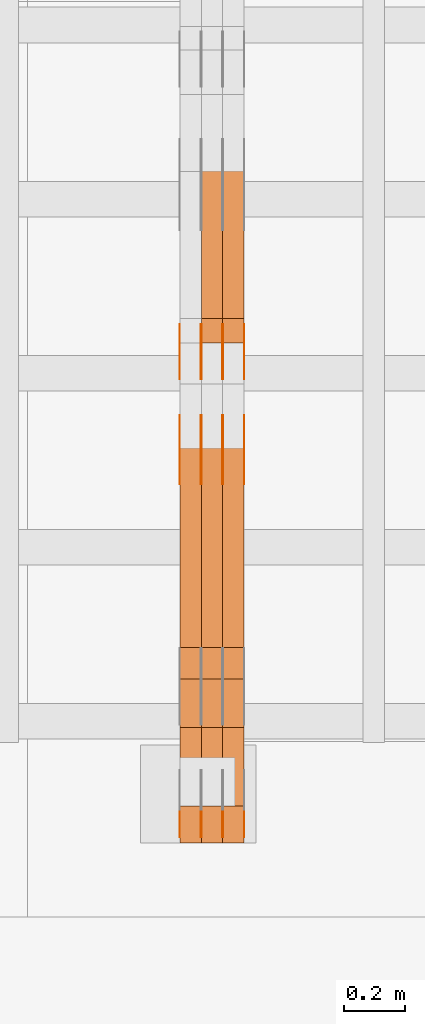
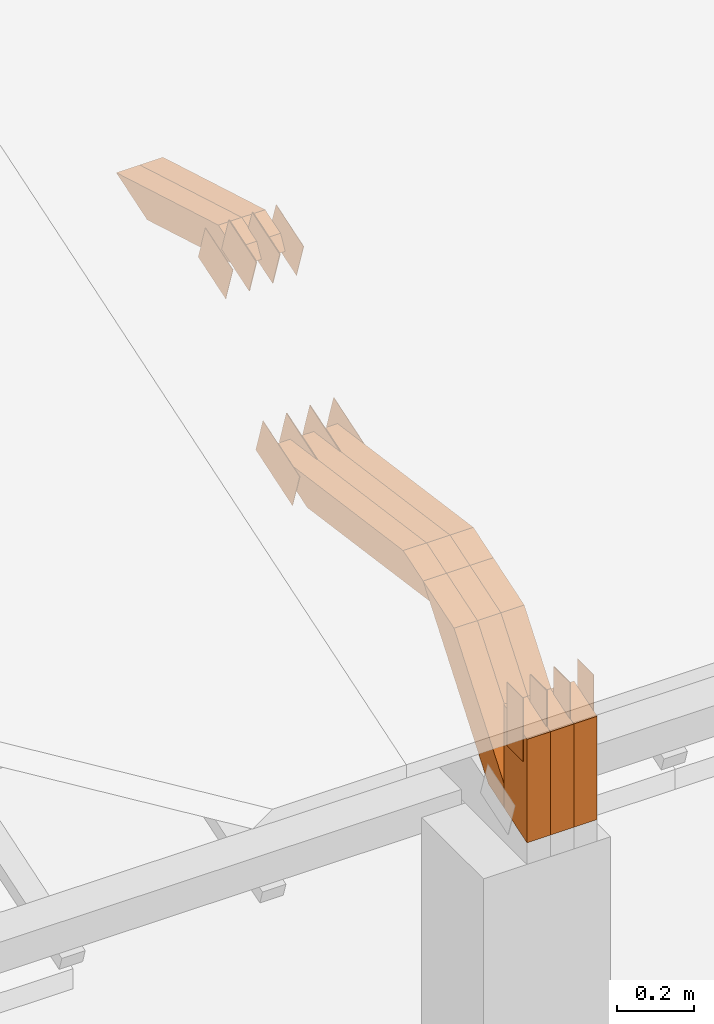
# One storey, part 40 of 385: 29 proxies.
"""IFC2X3 building model written with IfcOpenShell, lengths in millimetres."""

from ifc_helpers import new_model, entity, si_unit, converted_unit, derived_unit, direction, frame, frame_2d, origin, place, context, subcontext, project, spatial, polyline, rectangle, outline, extrude, source, transform, mapped, material, type_object, type_shapes, element, save


model = new_model("IFC2X3")

# Units and contexts
model_context = context("Model", 3, precision=0.01, world=origin(), true_north=direction((6.12303176911189e-17, 1.0)))
body_context = subcontext(model_context, "Body", "Model", "MODEL_VIEW")
ifc_project = project(units=[si_unit("LENGTHUNIT", "METRE", prefix="MILLI"), si_unit("AREAUNIT", "SQUARE_METRE"), si_unit("VOLUMEUNIT", "CUBIC_METRE"), converted_unit("PLANEANGLEUNIT", "DEGREE", entity("IfcRatioMeasure", 0.0174532925199433), si_unit("PLANEANGLEUNIT", "RADIAN"), dimensions=[0, 0, 0, 0, 0, 0, 0]), si_unit("MASSUNIT", "GRAM", prefix="KILO"), derived_unit("MASSDENSITYUNIT", [(si_unit("MASSUNIT", "GRAM", prefix="KILO"), 1), (si_unit("LENGTHUNIT", "METRE"), -3)]), si_unit("TIMEUNIT", "SECOND"), si_unit("FREQUENCYUNIT", "HERTZ"), si_unit("THERMODYNAMICTEMPERATUREUNIT", "DEGREE_CELSIUS"), derived_unit("THERMALTRANSMITTANCEUNIT", [(si_unit("MASSUNIT", "GRAM", prefix="KILO"), 1), (si_unit("THERMODYNAMICTEMPERATUREUNIT", "KELVIN"), -1), (si_unit("TIMEUNIT", "SECOND"), -3)]), derived_unit("VOLUMETRICFLOWRATEUNIT", [(si_unit("LENGTHUNIT", "METRE"), 3), (si_unit("TIMEUNIT", "SECOND"), -1)]), si_unit("ELECTRICCURRENTUNIT", "AMPERE"), si_unit("ELECTRICVOLTAGEUNIT", "VOLT"), si_unit("POWERUNIT", "WATT"), si_unit("FORCEUNIT", "NEWTON", prefix="KILO"), si_unit("ILLUMINANCEUNIT", "LUX"), si_unit("LUMINOUSFLUXUNIT", "LUMEN"), si_unit("LUMINOUSINTENSITYUNIT", "CANDELA"), derived_unit("USERDEFINED", [(si_unit("MASSUNIT", "GRAM", prefix="KILO"), -1), (si_unit("LENGTHUNIT", "METRE"), -2), (si_unit("TIMEUNIT", "SECOND"), 3), (si_unit("LUMINOUSFLUXUNIT", "LUMEN"), 1)]), derived_unit("LINEARVELOCITYUNIT", [(si_unit("LENGTHUNIT", "METRE"), 1), (si_unit("TIMEUNIT", "SECOND"), -1)]), si_unit("PRESSUREUNIT", "PASCAL"), derived_unit("USERDEFINED", [(si_unit("LENGTHUNIT", "METRE"), -2), (si_unit("MASSUNIT", "GRAM", prefix="KILO"), 1), (si_unit("TIMEUNIT", "SECOND"), -2)])], contexts=[model_context])

# Site, building, storey
site_placement = place(None, origin())
site = spatial("IfcSite", under=ifc_project, at=site_placement, CompositionType="ELEMENT")
building_placement = place(site_placement, origin())
building = spatial("IfcBuilding", under=site, at=building_placement, CompositionType="ELEMENT")
storey_placement = place(building_placement, origin())
storey = spatial("IfcBuildingStorey", under=building, at=storey_placement, Name="Default", CompositionType="ELEMENT", Elevation=0.0)

# Proxies
ifc_material_1 = material(Name="IfcSurfaceStyle #98662")
building_element_proxy_type_1 = type_object("IfcBuildingElementProxyType", PredefinedType="NOTDEFINED", material=ifc_material_1)
shared_shape_1 = source(origin(), body_context, "Body", "SweptSolid", [
    extrude(outline(polyline([(-99.9998204243802, -60.000067376167), (99.9998338462265, -60.000067376167), (99.9998204243802, 60.000067376167), (-99.9998338462265, 60.000067376167), (-99.9998204243802, -60.000067376167)])), frame((100.000602015329, 60.0001864986889, 0.0), z_axis=(0.0, 0.0, 1.0), x_axis=(-1.0, 0.0, 0.0)), (0.0, 0.0, 1.0), 1.3),
])
type_shapes(building_element_proxy_type_1, [shared_shape_1])
proxy_1_placement = place(building_placement, frame((6386.29999999999, 4114.85465165112, 513.097031388771), z_axis=(-1.0, 0.0, 0.0), x_axis=(0.0, 0.951056516295124, 0.309016994375039)))
element("IfcBuildingElementProxy", 1, at=proxy_1_placement, inside=storey, type_object=building_element_proxy_type_1, material=ifc_material_1, context=body_context, shape_type="MappedRepresentation", body=[
    mapped(shared_shape_1, transform((0.0, 0.0, 0.0), scale=1.0)),
])
ifc_material_2 = material(Name="IfcSurfaceStyle #98605")
building_element_proxy_type_2 = type_object("IfcBuildingElementProxyType", PredefinedType="NOTDEFINED", material=ifc_material_2)
shared_shape_2 = source(origin(), body_context, "Body", "SweptSolid", [
    extrude(outline(polyline([(-99.9998204243802, -60.000067376167), (99.9998338462265, -60.000067376167), (99.9998204243802, 60.000067376167), (-99.9998338462265, 60.000067376167), (-99.9998204243802, -60.000067376167)])), frame((100.000602015329, 60.0001864986889, 0.0), z_axis=(0.0, 0.0, 1.0), x_axis=(-1.0, 0.0, 0.0)), (0.0, 0.0, 1.0), 1.3),
])
type_shapes(building_element_proxy_type_2, [shared_shape_2])
proxy_2_placement = place(building_placement, frame((6315.0, 4114.85465165112, 513.097031388771), z_axis=(-1.0, 0.0, 0.0), x_axis=(0.0, 0.951056516295124, 0.309016994375039)))
element("IfcBuildingElementProxy", 2, at=proxy_2_placement, inside=storey, type_object=building_element_proxy_type_2, material=ifc_material_2, context=body_context, shape_type="MappedRepresentation", body=[
    mapped(shared_shape_2, transform((0.0, 0.0, 0.0), scale=1.0)),
])
ifc_material_3 = material(Name="IfcSurfaceStyle #98548")
building_element_proxy_type_3 = type_object("IfcBuildingElementProxyType", PredefinedType="NOTDEFINED", material=ifc_material_3)
shared_shape_3 = source(origin(), body_context, "Body", "SweptSolid", [
    extrude(outline(polyline([(-99.9998204243802, -60.000067376167), (99.9998338462265, -60.000067376167), (99.9998204243802, 60.000067376167), (-99.9998338462265, 60.000067376167), (-99.9998204243802, -60.000067376167)])), frame((100.000602015329, 60.0001864986889, 0.0), z_axis=(0.0, 0.0, 1.0), x_axis=(-1.0, 0.0, 0.0)), (0.0, 0.0, 1.0), 1.3),
])
type_shapes(building_element_proxy_type_3, [shared_shape_3])
proxy_3_placement = place(building_placement, frame((6316.29999999999, 4114.85465165112, 513.097031388771), z_axis=(-1.0, 0.0, 0.0), x_axis=(0.0, 0.951056516295124, 0.309016994375039)))
element("IfcBuildingElementProxy", 3, at=proxy_3_placement, inside=storey, type_object=building_element_proxy_type_3, material=ifc_material_3, context=body_context, shape_type="MappedRepresentation", body=[
    mapped(shared_shape_3, transform((0.0, 0.0, 0.0), scale=1.0)),
])
ifc_material_4 = material(Name="IfcSurfaceStyle #98491")
building_element_proxy_type_4 = type_object("IfcBuildingElementProxyType", PredefinedType="NOTDEFINED", material=ifc_material_4)
shared_shape_4 = source(origin(), body_context, "Body", "SweptSolid", [
    extrude(outline(polyline([(-99.9998204243802, -60.000067376167), (99.9998338462265, -60.000067376167), (99.9998204243802, 60.000067376167), (-99.9998338462265, 60.000067376167), (-99.9998204243802, -60.000067376167)])), frame((100.000602015329, 60.0001864986889, 0.0), z_axis=(0.0, 0.0, 1.0), x_axis=(-1.0, 0.0, 0.0)), (0.0, 0.0, 1.0), 1.29999999999998),
])
type_shapes(building_element_proxy_type_4, [shared_shape_4])
proxy_4_placement = place(building_placement, frame((6245.0, 4114.85465165112, 513.097031388771), z_axis=(-1.0, 0.0, 0.0), x_axis=(0.0, 0.951056516295124, 0.309016994375039)))
element("IfcBuildingElementProxy", 4, at=proxy_4_placement, inside=storey, type_object=building_element_proxy_type_4, material=ifc_material_4, context=body_context, shape_type="MappedRepresentation", body=[
    mapped(shared_shape_4, transform((0.0, 0.0, 0.0), scale=1.0)),
])
ifc_material_5 = material(Name="IfcSurfaceStyle #98434")
building_element_proxy_type_5 = type_object("IfcBuildingElementProxyType", PredefinedType="NOTDEFINED", material=ifc_material_5)
shared_shape_5 = source(origin(), body_context, "Body", "SweptSolid", [
    extrude(outline(polyline([(-99.9998204243802, -60.000067376167), (99.9998338462265, -60.000067376167), (99.9998204243802, 60.000067376167), (-99.9998338462265, 60.000067376167), (-99.9998204243802, -60.000067376167)])), frame((100.000602015329, 60.0001864986889, 0.0), z_axis=(0.0, 0.0, 1.0), x_axis=(-1.0, 0.0, 0.0)), (0.0, 0.0, 1.0), 1.29999999999998),
])
type_shapes(building_element_proxy_type_5, [shared_shape_5])
proxy_5_placement = place(building_placement, frame((6246.29999999999, 4114.85465165112, 513.097031388771), z_axis=(-1.0, 0.0, 0.0), x_axis=(0.0, 0.951056516295124, 0.309016994375039)))
element("IfcBuildingElementProxy", 5, at=proxy_5_placement, inside=storey, type_object=building_element_proxy_type_5, material=ifc_material_5, context=body_context, shape_type="MappedRepresentation", body=[
    mapped(shared_shape_5, transform((0.0, 0.0, 0.0), scale=1.0)),
])
ifc_material_6 = material(Name="IfcSurfaceStyle #98377")
building_element_proxy_type_6 = type_object("IfcBuildingElementProxyType", PredefinedType="NOTDEFINED", material=ifc_material_6)
shared_shape_6 = source(origin(), body_context, "Body", "SweptSolid", [
    extrude(outline(polyline([(-99.9998204243802, -60.000067376167), (99.9998338462265, -60.000067376167), (99.9998204243802, 60.000067376167), (-99.9998338462265, 60.000067376167), (-99.9998204243802, -60.000067376167)])), frame((100.000602015329, 60.0001864986889, 0.0), z_axis=(0.0, 0.0, 1.0), x_axis=(-1.0, 0.0, 0.0)), (0.0, 0.0, 1.0), 1.29999999999999),
])
type_shapes(building_element_proxy_type_6, [shared_shape_6])
proxy_6_placement = place(building_placement, frame((6175.0, 4114.85465165112, 513.097031388771), z_axis=(-1.0, 0.0, 0.0), x_axis=(0.0, 0.951056516295124, 0.309016994375039)))
element("IfcBuildingElementProxy", 6, at=proxy_6_placement, inside=storey, type_object=building_element_proxy_type_6, material=ifc_material_6, context=body_context, shape_type="MappedRepresentation", body=[
    mapped(shared_shape_6, transform((0.0, 0.0, 0.0), scale=1.0)),
])
ifc_material_7 = material(Name="IfcSurfaceStyle #91480")
building_element_proxy_type_7 = type_object("IfcBuildingElementProxyType", PredefinedType="NOTDEFINED", material=ifc_material_7)
shared_shape_7 = source(origin(), body_context, "Body", "SweptSolid", [
    extrude(outline(polyline([(-74.999865998172, -60.0000306612919), (74.999869989555, -60.0000306612919), (74.999865998172, 60.0000306612919), (-74.999869989555, 60.0000306612919), (-74.999865998172, -60.0000306612919)])), frame((75.0006726017528, 60.0001996460842, 0.0), z_axis=(0.0, 0.0, 1.0), x_axis=(-1.0, 0.0, 0.0)), (0.0, 0.0, 1.0), 1.3),
])
type_shapes(building_element_proxy_type_7, [shared_shape_7])
proxy_7_placement = place(building_placement, frame((6386.29999999999, 4460.38978242656, 957.314497110567), z_axis=(-1.0, 0.0, 0.0), x_axis=(0.0, 0.951056516295154, 0.309016994374948)))
element("IfcBuildingElementProxy", 7, at=proxy_7_placement, inside=storey, type_object=building_element_proxy_type_7, material=ifc_material_7, context=body_context, shape_type="MappedRepresentation", body=[
    mapped(shared_shape_7, transform((0.0, 0.0, 0.0), scale=1.0)),
])
ifc_material_8 = material(Name="IfcSurfaceStyle #91423")
building_element_proxy_type_8 = type_object("IfcBuildingElementProxyType", PredefinedType="NOTDEFINED", material=ifc_material_8)
shared_shape_8 = source(origin(), body_context, "Body", "SweptSolid", [
    extrude(outline(polyline([(-74.999865998172, -60.0000306612919), (74.999869989555, -60.0000306612919), (74.999865998172, 60.0000306612919), (-74.999869989555, 60.0000306612919), (-74.999865998172, -60.0000306612919)])), frame((75.0006726017528, 60.0001996460842, 0.0), z_axis=(0.0, 0.0, 1.0), x_axis=(-1.0, 0.0, 0.0)), (0.0, 0.0, 1.0), 1.3),
])
type_shapes(building_element_proxy_type_8, [shared_shape_8])
proxy_8_placement = place(building_placement, frame((6315.0, 4460.38978242656, 957.314497110567), z_axis=(-1.0, 0.0, 0.0), x_axis=(0.0, 0.951056516295154, 0.309016994374948)))
element("IfcBuildingElementProxy", 8, at=proxy_8_placement, inside=storey, type_object=building_element_proxy_type_8, material=ifc_material_8, context=body_context, shape_type="MappedRepresentation", body=[
    mapped(shared_shape_8, transform((0.0, 0.0, 0.0), scale=1.0)),
])
ifc_material_9 = material(Name="IfcSurfaceStyle #91366")
building_element_proxy_type_9 = type_object("IfcBuildingElementProxyType", PredefinedType="NOTDEFINED", material=ifc_material_9)
shared_shape_9 = source(origin(), body_context, "Body", "SweptSolid", [
    extrude(outline(polyline([(-74.999865998172, -60.0000306612919), (74.999869989555, -60.0000306612919), (74.999865998172, 60.0000306612919), (-74.999869989555, 60.0000306612919), (-74.999865998172, -60.0000306612919)])), frame((75.0006726017528, 60.0001996460842, 0.0), z_axis=(0.0, 0.0, 1.0), x_axis=(-1.0, 0.0, 0.0)), (0.0, 0.0, 1.0), 1.3),
])
type_shapes(building_element_proxy_type_9, [shared_shape_9])
proxy_9_placement = place(building_placement, frame((6316.29999999999, 4460.38978242656, 957.314497110567), z_axis=(-1.0, 0.0, 0.0), x_axis=(0.0, 0.951056516295154, 0.309016994374948)))
element("IfcBuildingElementProxy", 9, at=proxy_9_placement, inside=storey, type_object=building_element_proxy_type_9, material=ifc_material_9, context=body_context, shape_type="MappedRepresentation", body=[
    mapped(shared_shape_9, transform((0.0, 0.0, 0.0), scale=1.0)),
])
ifc_material_10 = material(Name="IfcSurfaceStyle #91309")
building_element_proxy_type_10 = type_object("IfcBuildingElementProxyType", PredefinedType="NOTDEFINED", material=ifc_material_10)
shared_shape_10 = source(origin(), body_context, "Body", "SweptSolid", [
    extrude(outline(polyline([(-74.999865998172, -60.0000306612919), (74.999869989555, -60.0000306612919), (74.999865998172, 60.0000306612919), (-74.999869989555, 60.0000306612919), (-74.999865998172, -60.0000306612919)])), frame((75.0006726017528, 60.0001996460842, 0.0), z_axis=(0.0, 0.0, 1.0), x_axis=(-1.0, 0.0, 0.0)), (0.0, 0.0, 1.0), 1.29999999999999),
])
type_shapes(building_element_proxy_type_10, [shared_shape_10])
proxy_10_placement = place(building_placement, frame((6245.0, 4460.38978242656, 957.314497110567), z_axis=(-1.0, 0.0, 0.0), x_axis=(0.0, 0.951056516295154, 0.309016994374948)))
element("IfcBuildingElementProxy", 10, at=proxy_10_placement, inside=storey, type_object=building_element_proxy_type_10, material=ifc_material_10, context=body_context, shape_type="MappedRepresentation", body=[
    mapped(shared_shape_10, transform((0.0, 0.0, 0.0), scale=1.0)),
])
ifc_material_11 = material(Name="IfcSurfaceStyle #91252")
building_element_proxy_type_11 = type_object("IfcBuildingElementProxyType", PredefinedType="NOTDEFINED", material=ifc_material_11)
shared_shape_11 = source(origin(), body_context, "Body", "SweptSolid", [
    extrude(outline(polyline([(-74.999865998172, -60.0000306612919), (74.999869989555, -60.0000306612919), (74.999865998172, 60.0000306612919), (-74.999869989555, 60.0000306612919), (-74.999865998172, -60.0000306612919)])), frame((75.0006726017528, 60.0001996460842, 0.0), z_axis=(0.0, 0.0, 1.0), x_axis=(-1.0, 0.0, 0.0)), (0.0, 0.0, 1.0), 1.29999999999999),
])
type_shapes(building_element_proxy_type_11, [shared_shape_11])
proxy_11_placement = place(building_placement, frame((6246.29999999999, 4460.38978242656, 957.314497110567), z_axis=(-1.0, 0.0, 0.0), x_axis=(0.0, 0.951056516295154, 0.309016994374948)))
element("IfcBuildingElementProxy", 11, at=proxy_11_placement, inside=storey, type_object=building_element_proxy_type_11, material=ifc_material_11, context=body_context, shape_type="MappedRepresentation", body=[
    mapped(shared_shape_11, transform((0.0, 0.0, 0.0), scale=1.0)),
])
ifc_material_12 = material(Name="IfcSurfaceStyle #91195")
building_element_proxy_type_12 = type_object("IfcBuildingElementProxyType", PredefinedType="NOTDEFINED", material=ifc_material_12)
shared_shape_12 = source(origin(), body_context, "Body", "SweptSolid", [
    extrude(outline(polyline([(-74.999865998172, -60.0000306612919), (74.999869989555, -60.0000306612919), (74.999865998172, 60.0000306612919), (-74.999869989555, 60.0000306612919), (-74.999865998172, -60.0000306612919)])), frame((75.0006726017528, 60.0001996460842, 0.0), z_axis=(0.0, 0.0, 1.0), x_axis=(-1.0, 0.0, 0.0)), (0.0, 0.0, 1.0), 1.29999999999999),
])
type_shapes(building_element_proxy_type_12, [shared_shape_12])
proxy_12_placement = place(building_placement, frame((6175.0, 4460.38978242656, 957.314497110567), z_axis=(-1.0, 0.0, 0.0), x_axis=(0.0, 0.951056516295154, 0.309016994374948)))
element("IfcBuildingElementProxy", 12, at=proxy_12_placement, inside=storey, type_object=building_element_proxy_type_12, material=ifc_material_12, context=body_context, shape_type="MappedRepresentation", body=[
    mapped(shared_shape_12, transform((0.0, 0.0, 0.0), scale=1.0)),
])
ifc_material_13 = material(Name="IfcSurfaceStyle #89428")
building_element_proxy_type_13 = type_object("IfcBuildingElementProxyType", PredefinedType="NOTDEFINED", material=ifc_material_13)
shared_shape_13 = source(origin(), body_context, "Body", "SweptSolid", [
    extrude(rectangle(XDim=199.999969482422, YDim=84.0, at=frame_2d((1.4210854715202e-14, 0.0), x_axis=(1.0, 0.0))), frame((100.000010815955, 42.0, 0.0), z_axis=(0.0, 0.0, 1.0), x_axis=(-1.0, 0.0, 0.0)), (0.0, 0.0, 1.0), 1.3),
])
type_shapes(building_element_proxy_type_13, [shared_shape_13])
proxy_13_placement = place(building_placement, frame((6386.29999999999, 3042.0, 514.460048047401), z_axis=(-1.0, 0.0, 0.0), x_axis=(0.0, 0.0, -1.0)))
element("IfcBuildingElementProxy", 13, at=proxy_13_placement, inside=storey, type_object=building_element_proxy_type_13, material=ifc_material_13, context=body_context, shape_type="MappedRepresentation", body=[
    mapped(shared_shape_13, transform((0.0, 0.0, 0.0), scale=1.0)),
])
ifc_material_14 = material(Name="IfcSurfaceStyle #89371")
building_element_proxy_type_14 = type_object("IfcBuildingElementProxyType", PredefinedType="NOTDEFINED", material=ifc_material_14)
shared_shape_14 = source(origin(), body_context, "Body", "SweptSolid", [
    extrude(rectangle(XDim=199.999969482422, YDim=84.0, at=frame_2d((1.4210854715202e-14, 0.0), x_axis=(1.0, 0.0))), frame((100.000010815955, 42.0, 0.0), z_axis=(0.0, 0.0, 1.0), x_axis=(-1.0, 0.0, 0.0)), (0.0, 0.0, 1.0), 1.3),
])
type_shapes(building_element_proxy_type_14, [shared_shape_14])
proxy_14_placement = place(building_placement, frame((6315.0, 3042.0, 514.460048047401), z_axis=(-1.0, 0.0, 0.0), x_axis=(0.0, 0.0, -1.0)))
element("IfcBuildingElementProxy", 14, at=proxy_14_placement, inside=storey, type_object=building_element_proxy_type_14, material=ifc_material_14, context=body_context, shape_type="MappedRepresentation", body=[
    mapped(shared_shape_14, transform((0.0, 0.0, 0.0), scale=1.0)),
])
ifc_material_15 = material(Name="IfcSurfaceStyle #89314")
building_element_proxy_type_15 = type_object("IfcBuildingElementProxyType", PredefinedType="NOTDEFINED", material=ifc_material_15)
shared_shape_15 = source(origin(), body_context, "Body", "SweptSolid", [
    extrude(rectangle(XDim=199.999969482422, YDim=84.0, at=frame_2d((1.4210854715202e-14, 0.0), x_axis=(1.0, 0.0))), frame((100.000010815955, 42.0, 0.0), z_axis=(0.0, 0.0, 1.0), x_axis=(-1.0, 0.0, 0.0)), (0.0, 0.0, 1.0), 1.3),
])
type_shapes(building_element_proxy_type_15, [shared_shape_15])
proxy_15_placement = place(building_placement, frame((6316.29999999999, 3042.0, 514.460048047401), z_axis=(-1.0, 0.0, 0.0), x_axis=(0.0, 0.0, -1.0)))
element("IfcBuildingElementProxy", 15, at=proxy_15_placement, inside=storey, type_object=building_element_proxy_type_15, material=ifc_material_15, context=body_context, shape_type="MappedRepresentation", body=[
    mapped(shared_shape_15, transform((0.0, 0.0, 0.0), scale=1.0)),
])
ifc_material_16 = material(Name="IfcSurfaceStyle #89257")
building_element_proxy_type_16 = type_object("IfcBuildingElementProxyType", PredefinedType="NOTDEFINED", material=ifc_material_16)
shared_shape_16 = source(origin(), body_context, "Body", "SweptSolid", [
    extrude(rectangle(XDim=199.999969482422, YDim=84.0, at=frame_2d((1.4210854715202e-14, 0.0), x_axis=(1.0, 0.0))), frame((100.000010815955, 42.0, 0.0), z_axis=(0.0, 0.0, 1.0), x_axis=(-1.0, 0.0, 0.0)), (0.0, 0.0, 1.0), 1.29999999999998),
])
type_shapes(building_element_proxy_type_16, [shared_shape_16])
proxy_16_placement = place(building_placement, frame((6245.0, 3042.0, 514.460048047401), z_axis=(-1.0, 0.0, 0.0), x_axis=(0.0, 0.0, -1.0)))
element("IfcBuildingElementProxy", 16, at=proxy_16_placement, inside=storey, type_object=building_element_proxy_type_16, material=ifc_material_16, context=body_context, shape_type="MappedRepresentation", body=[
    mapped(shared_shape_16, transform((0.0, 0.0, 0.0), scale=1.0)),
])
ifc_material_17 = material(Name="IfcSurfaceStyle #89200")
building_element_proxy_type_17 = type_object("IfcBuildingElementProxyType", PredefinedType="NOTDEFINED", material=ifc_material_17)
shared_shape_17 = source(origin(), body_context, "Body", "SweptSolid", [
    extrude(rectangle(XDim=199.999969482422, YDim=84.0, at=frame_2d((1.4210854715202e-14, 0.0), x_axis=(1.0, 0.0))), frame((100.000010815955, 42.0, 0.0), z_axis=(0.0, 0.0, 1.0), x_axis=(-1.0, 0.0, 0.0)), (0.0, 0.0, 1.0), 1.29999999999998),
])
type_shapes(building_element_proxy_type_17, [shared_shape_17])
proxy_17_placement = place(building_placement, frame((6246.29999999999, 3042.0, 514.460048047401), z_axis=(-1.0, 0.0, 0.0), x_axis=(0.0, 0.0, -1.0)))
element("IfcBuildingElementProxy", 17, at=proxy_17_placement, inside=storey, type_object=building_element_proxy_type_17, material=ifc_material_17, context=body_context, shape_type="MappedRepresentation", body=[
    mapped(shared_shape_17, transform((0.0, 0.0, 0.0), scale=1.0)),
])
ifc_material_18 = material(Name="IfcSurfaceStyle #89143")
building_element_proxy_type_18 = type_object("IfcBuildingElementProxyType", PredefinedType="NOTDEFINED", material=ifc_material_18)
shared_shape_18 = source(origin(), body_context, "Body", "SweptSolid", [
    extrude(rectangle(XDim=199.999969482422, YDim=84.0, at=frame_2d((1.4210854715202e-14, 0.0), x_axis=(1.0, 0.0))), frame((100.000010815955, 42.0, 0.0), z_axis=(0.0, 0.0, 1.0), x_axis=(-1.0, 0.0, 0.0)), (0.0, 0.0, 1.0), 1.29999999999999),
])
type_shapes(building_element_proxy_type_18, [shared_shape_18])
proxy_18_placement = place(building_placement, frame((6175.0, 3042.0, 514.460048047401), z_axis=(-1.0, 0.0, 0.0), x_axis=(0.0, 0.0, -1.0)))
element("IfcBuildingElementProxy", 18, at=proxy_18_placement, inside=storey, type_object=building_element_proxy_type_18, material=ifc_material_18, context=body_context, shape_type="MappedRepresentation", body=[
    mapped(shared_shape_18, transform((0.0, 0.0, 0.0), scale=1.0)),
])
ifc_material_19 = material(Name="IfcSurfaceStyle #78952")
building_element_proxy_type_19 = type_object("IfcBuildingElementProxyType", Name="T1-W12 78950", PredefinedType="NOTDEFINED", material=ifc_material_19)
shared_shape_19 = source(origin(), body_context, "Body", "SweptSolid", [
    extrude(outline(polyline([(-249.405625983165, -47.5001691155616), (243.345753908996, -47.5001691155616), (232.115534842595, 2.39993474701938e-05), (162.527010966644, 47.5001571158879), (-388.58267373507, 47.5001571158879), (-249.405625983165, -47.5001691155616)])), frame((243.345867653852, 47.5001571158879, 0.0), z_axis=(0.0, 0.0, 1.0), x_axis=(-1.0, 0.0, 0.0)), (0.0, 0.0, 1.0), 70.0),
])
type_shapes(building_element_proxy_type_19, [shared_shape_19])
proxy_19_placement = place(building_placement, frame((6385.0, 4581.32698473632, 976.172276753357), z_axis=(-1.0, 0.0, 0.0), x_axis=(0.0, 0.959722067881787, -0.280951156645966)))
element("IfcBuildingElementProxy", 19, at=proxy_19_placement, inside=storey, type_object=building_element_proxy_type_19, material=ifc_material_19, Name="T1-W12", context=body_context, shape_type="MappedRepresentation", body=[
    mapped(shared_shape_19, transform((0.0, 0.0, 0.0), scale=1.0)),
])
ifc_material_20 = material(Name="IfcSurfaceStyle #78886")
building_element_proxy_type_20 = type_object("IfcBuildingElementProxyType", Name="T1-W12 78884", PredefinedType="NOTDEFINED", material=ifc_material_20)
shared_shape_20 = source(origin(), body_context, "Body", "SweptSolid", [
    extrude(outline(polyline([(-249.405625983165, -47.5001691155616), (243.345753908996, -47.5001691155616), (232.115534842595, 2.39993474701938e-05), (162.527010966644, 47.5001571158879), (-388.58267373507, 47.5001571158879), (-249.405625983165, -47.5001691155616)])), frame((243.345867653852, 47.5001571158879, 0.0), z_axis=(0.0, 0.0, 1.0), x_axis=(-1.0, 0.0, 0.0)), (0.0, 0.0, 1.0), 70.0),
])
type_shapes(building_element_proxy_type_20, [shared_shape_20])
proxy_20_placement = place(building_placement, frame((6315.0, 4581.32698473632, 976.172276753357), z_axis=(-1.0, 0.0, 0.0), x_axis=(0.0, 0.959722067881787, -0.280951156645966)))
element("IfcBuildingElementProxy", 20, at=proxy_20_placement, inside=storey, type_object=building_element_proxy_type_20, material=ifc_material_20, Name="T1-W12", context=body_context, shape_type="MappedRepresentation", body=[
    mapped(shared_shape_20, transform((0.0, 0.0, 0.0), scale=1.0)),
])
ifc_material_21 = material(Name="IfcSurfaceStyle #78160")
building_element_proxy_type_21 = type_object("IfcBuildingElementProxyType", Name="T1-W3 78158", PredefinedType="NOTDEFINED", material=ifc_material_21)
shared_shape_21 = source(origin(), body_context, "Body", "SweptSolid", [
    extrude(outline(polyline([(-314.232579911788, -47.5000200125938), (325.164873061766, -47.5000200125938), (297.999869081008, 6.48085173424295e-05), (200.434027234171, 47.4999876083351), (-509.366189465157, 47.4999876083352), (-314.232579911788, -47.5000200125938)])), frame((325.164873061766, 47.5001564752191, 0.0), z_axis=(0.0, 0.0, 1.0), x_axis=(-1.0, 0.0, 0.0)), (0.0, 0.0, 1.0), 70.0),
])
type_shapes(building_element_proxy_type_21, [shared_shape_21])
proxy_21_placement = place(building_placement, frame((6385.0, 3457.43747924876, 620.49890325051), z_axis=(-1.0, 0.0, 0.0), x_axis=(0.0, 0.990367219823621, -0.138465771578512)))
element("IfcBuildingElementProxy", 21, at=proxy_21_placement, inside=storey, type_object=building_element_proxy_type_21, material=ifc_material_21, Name="T1-W3", context=body_context, shape_type="MappedRepresentation", body=[
    mapped(shared_shape_21, transform((0.0, 0.0, 0.0), scale=1.0)),
])
ifc_material_22 = material(Name="IfcSurfaceStyle #78094")
building_element_proxy_type_22 = type_object("IfcBuildingElementProxyType", Name="T1-W3 78092", PredefinedType="NOTDEFINED", material=ifc_material_22)
shared_shape_22 = source(origin(), body_context, "Body", "SweptSolid", [
    extrude(outline(polyline([(-314.232579911788, -47.5000200125938), (325.164873061766, -47.5000200125938), (297.999869081008, 6.48085173424295e-05), (200.434027234171, 47.4999876083351), (-509.366189465157, 47.4999876083352), (-314.232579911788, -47.5000200125938)])), frame((325.164873061766, 47.5001564752191, 0.0), z_axis=(0.0, 0.0, 1.0), x_axis=(-1.0, 0.0, 0.0)), (0.0, 0.0, 1.0), 70.0),
])
type_shapes(building_element_proxy_type_22, [shared_shape_22])
proxy_22_placement = place(building_placement, frame((6315.0, 3457.43747924876, 620.49890325051), z_axis=(-1.0, 0.0, 0.0), x_axis=(0.0, 0.990367219823621, -0.138465771578512)))
element("IfcBuildingElementProxy", 22, at=proxy_22_placement, inside=storey, type_object=building_element_proxy_type_22, material=ifc_material_22, Name="T1-W3", context=body_context, shape_type="MappedRepresentation", body=[
    mapped(shared_shape_22, transform((0.0, 0.0, 0.0), scale=1.0)),
])
ifc_material_23 = material(Name="IfcSurfaceStyle #78028")
building_element_proxy_type_23 = type_object("IfcBuildingElementProxyType", Name="T1-W3 78026", PredefinedType="NOTDEFINED", material=ifc_material_23)
shared_shape_23 = source(origin(), body_context, "Body", "SweptSolid", [
    extrude(outline(polyline([(-314.232579911788, -47.5000200125938), (325.164873061766, -47.5000200125938), (297.999869081008, 6.48085173424295e-05), (200.434027234171, 47.4999876083351), (-509.366189465157, 47.4999876083352), (-314.232579911788, -47.5000200125938)])), frame((325.164873061766, 47.5001564752191, 0.0), z_axis=(0.0, 0.0, 1.0), x_axis=(-1.0, 0.0, 0.0)), (0.0, 0.0, 1.0), 70.0),
])
type_shapes(building_element_proxy_type_23, [shared_shape_23])
proxy_23_placement = place(building_placement, frame((6245.0, 3457.43747924876, 620.49890325051), z_axis=(-1.0, 0.0, 0.0), x_axis=(0.0, 0.990367219823621, -0.138465771578512)))
element("IfcBuildingElementProxy", 23, at=proxy_23_placement, inside=storey, type_object=building_element_proxy_type_23, material=ifc_material_23, Name="T1-W3", context=body_context, shape_type="MappedRepresentation", body=[
    mapped(shared_shape_23, transform((0.0, 0.0, 0.0), scale=1.0)),
])
ifc_material_24 = material(Name="IfcSurfaceStyle #77764")
building_element_proxy_type_24 = type_object("IfcBuildingElementProxyType", Name="T1-W14 77762", PredefinedType="NOTDEFINED", material=ifc_material_24)
shared_shape_24 = source(origin(), body_context, "Body", "SweptSolid", [
    extrude(outline(polyline([(-374.484689776928, -47.499919737532), (177.199556189275, -47.499919737532), (246.893257937645, -5.36774925340877e-05), (185.487930694801, 47.4999465762783), (-235.096055044793, 47.4999465762784), (-374.484689776928, -47.499919737532)])), frame((246.893257937645, 47.5000959779252, 0.0), z_axis=(0.0, 0.0, 1.0), x_axis=(-1.0, 0.0, 0.0)), (0.0, 0.0, 1.0), 70.0),
])
type_shapes(building_element_proxy_type_24, [shared_shape_24])
proxy_24_placement = place(building_placement, frame((6385.0, 3022.42877773025, 136.329406512195), z_axis=(-1.0, 0.0, 0.0), x_axis=(0.0, 0.611854146609475, 0.790970608352037)))
element("IfcBuildingElementProxy", 24, at=proxy_24_placement, inside=storey, type_object=building_element_proxy_type_24, material=ifc_material_24, Name="T1-W14", context=body_context, shape_type="MappedRepresentation", body=[
    mapped(shared_shape_24, transform((0.0, 0.0, 0.0), scale=1.0)),
])
ifc_material_25 = material(Name="IfcSurfaceStyle #77698")
building_element_proxy_type_25 = type_object("IfcBuildingElementProxyType", Name="T1-W14 77696", PredefinedType="NOTDEFINED", material=ifc_material_25)
shared_shape_25 = source(origin(), body_context, "Body", "SweptSolid", [
    extrude(outline(polyline([(-374.484689776928, -47.499919737532), (177.199556189275, -47.499919737532), (246.893257937645, -5.36774925340877e-05), (185.487930694801, 47.4999465762783), (-235.096055044793, 47.4999465762784), (-374.484689776928, -47.499919737532)])), frame((246.893257937645, 47.5000959779252, 0.0), z_axis=(0.0, 0.0, 1.0), x_axis=(-1.0, 0.0, 0.0)), (0.0, 0.0, 1.0), 70.0),
])
type_shapes(building_element_proxy_type_25, [shared_shape_25])
proxy_25_placement = place(building_placement, frame((6315.0, 3022.42877773025, 136.329406512195), z_axis=(-1.0, 0.0, 0.0), x_axis=(0.0, 0.611854146609475, 0.790970608352037)))
element("IfcBuildingElementProxy", 25, at=proxy_25_placement, inside=storey, type_object=building_element_proxy_type_25, material=ifc_material_25, Name="T1-W14", context=body_context, shape_type="MappedRepresentation", body=[
    mapped(shared_shape_25, transform((0.0, 0.0, 0.0), scale=1.0)),
])
ifc_material_26 = material(Name="IfcSurfaceStyle #77632")
building_element_proxy_type_26 = type_object("IfcBuildingElementProxyType", Name="T1-W14 77630", PredefinedType="NOTDEFINED", material=ifc_material_26)
shared_shape_26 = source(origin(), body_context, "Body", "SweptSolid", [
    extrude(outline(polyline([(-374.484689776928, -47.499919737532), (177.199556189275, -47.499919737532), (246.893257937645, -5.36774925340877e-05), (185.487930694801, 47.4999465762783), (-235.096055044793, 47.4999465762784), (-374.484689776928, -47.499919737532)])), frame((246.893257937645, 47.5000959779252, 0.0), z_axis=(0.0, 0.0, 1.0), x_axis=(-1.0, 0.0, 0.0)), (0.0, 0.0, 1.0), 70.0),
])
type_shapes(building_element_proxy_type_26, [shared_shape_26])
proxy_26_placement = place(building_placement, frame((6245.0, 3022.42877773025, 136.329406512195), z_axis=(-1.0, 0.0, 0.0), x_axis=(0.0, 0.611854146609475, 0.790970608352037)))
element("IfcBuildingElementProxy", 26, at=proxy_26_placement, inside=storey, type_object=building_element_proxy_type_26, material=ifc_material_26, Name="T1-W14", context=body_context, shape_type="MappedRepresentation", body=[
    mapped(shared_shape_26, transform((0.0, 0.0, 0.0), scale=1.0)),
])
ifc_material_27 = material(Name="IfcSurfaceStyle #77566")
building_element_proxy_type_27 = type_object("IfcBuildingElementProxyType", Name="T1-E3 77564", PredefinedType="NOTDEFINED", material=ifc_material_27)
shared_shape_27 = source(origin(), body_context, "Body", "SweptSolid", [
    extrude(outline(polyline([(-182.839673995971, -60.0), (143.849313735962, -60.0), (182.839677810669, 60.0), (-143.84931755066, 60.0), (-182.839673995971, -60.0)])), frame((182.839677810669, 60.0, 0.0), z_axis=(0.0, 0.0, 1.0), x_axis=(-1.0, 0.0, 0.0)), (0.0, 0.0, 1.0), 70.0),
])
type_shapes(building_element_proxy_type_27, [shared_shape_27])
proxy_27_placement = place(building_placement, frame((6385.0, 2940.0, 68.27587890625), z_axis=(-1.0, 0.0, 0.0), x_axis=(0.0, 0.0, 1.0)))
element("IfcBuildingElementProxy", 27, at=proxy_27_placement, inside=storey, type_object=building_element_proxy_type_27, material=ifc_material_27, Name="T1-E3", context=body_context, shape_type="MappedRepresentation", body=[
    mapped(shared_shape_27, transform((0.0, 0.0, 0.0), scale=1.0)),
])
ifc_material_28 = material(Name="IfcSurfaceStyle #77509")
building_element_proxy_type_28 = type_object("IfcBuildingElementProxyType", Name="T1-E3 77507", PredefinedType="NOTDEFINED", material=ifc_material_28)
shared_shape_28 = source(origin(), body_context, "Body", "SweptSolid", [
    extrude(outline(polyline([(-182.839673995971, -60.0), (143.849313735962, -60.0), (182.839677810669, 60.0), (-143.84931755066, 60.0), (-182.839673995971, -60.0)])), frame((182.839677810669, 60.0, 0.0), z_axis=(0.0, 0.0, 1.0), x_axis=(-1.0, 0.0, 0.0)), (0.0, 0.0, 1.0), 70.0),
])
type_shapes(building_element_proxy_type_28, [shared_shape_28])
proxy_28_placement = place(building_placement, frame((6315.0, 2940.0, 68.27587890625), z_axis=(-1.0, 0.0, 0.0), x_axis=(0.0, 0.0, 1.0)))
element("IfcBuildingElementProxy", 28, at=proxy_28_placement, inside=storey, type_object=building_element_proxy_type_28, material=ifc_material_28, Name="T1-E3", context=body_context, shape_type="MappedRepresentation", body=[
    mapped(shared_shape_28, transform((0.0, 0.0, 0.0), scale=1.0)),
])
ifc_material_29 = material(Name="IfcSurfaceStyle #77452")
building_element_proxy_type_29 = type_object("IfcBuildingElementProxyType", Name="T1-E3 77450", PredefinedType="NOTDEFINED", material=ifc_material_29)
shared_shape_29 = source(origin(), body_context, "Body", "SweptSolid", [
    extrude(outline(polyline([(-182.839673995971, -60.0), (143.849313735962, -60.0), (182.839677810669, 60.0), (-143.84931755066, 60.0), (-182.839673995971, -60.0)])), frame((182.839677810669, 60.0, 0.0), z_axis=(0.0, 0.0, 1.0), x_axis=(-1.0, 0.0, 0.0)), (0.0, 0.0, 1.0), 70.0),
])
type_shapes(building_element_proxy_type_29, [shared_shape_29])
proxy_29_placement = place(building_placement, frame((6245.0, 2940.0, 68.27587890625), z_axis=(-1.0, 0.0, 0.0), x_axis=(0.0, 0.0, 1.0)))
element("IfcBuildingElementProxy", 29, at=proxy_29_placement, inside=storey, type_object=building_element_proxy_type_29, material=ifc_material_29, Name="T1-E3", context=body_context, shape_type="MappedRepresentation", body=[
    mapped(shared_shape_29, transform((0.0, 0.0, 0.0), scale=1.0)),
])

save(model, "model.ifc")
